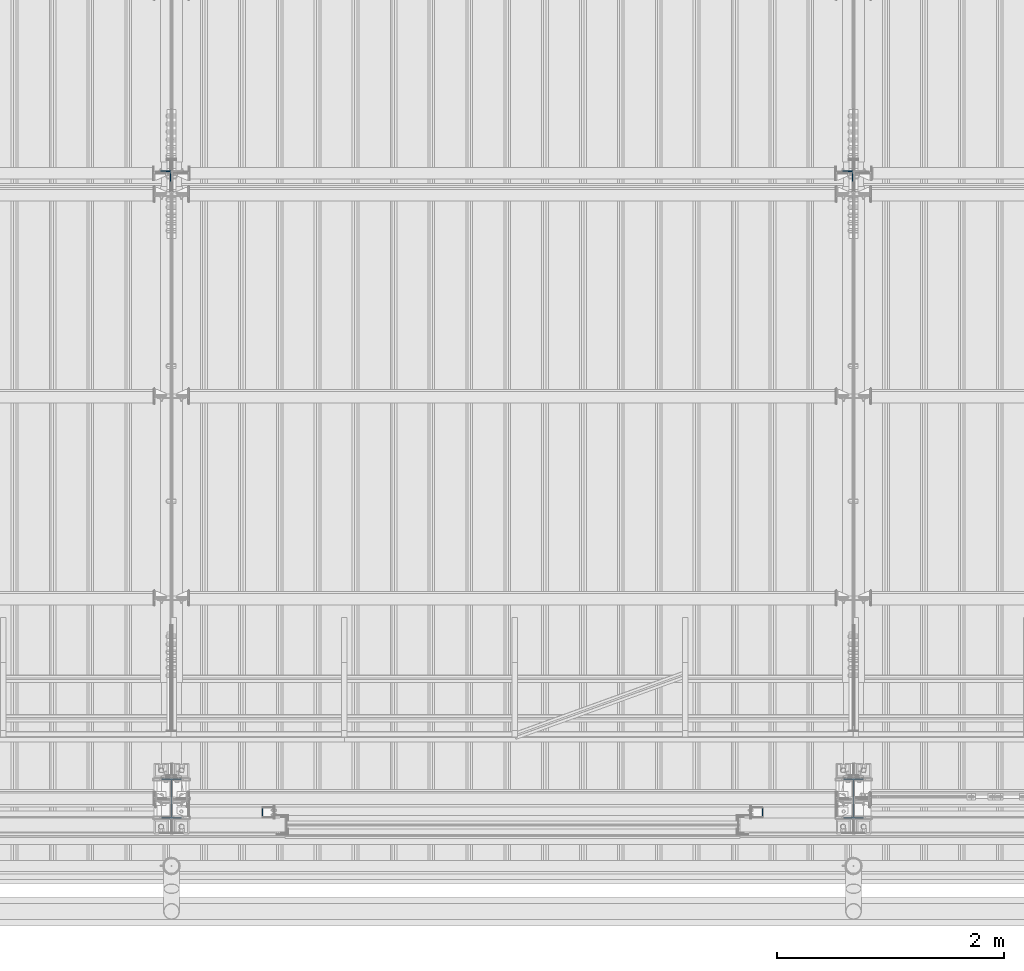
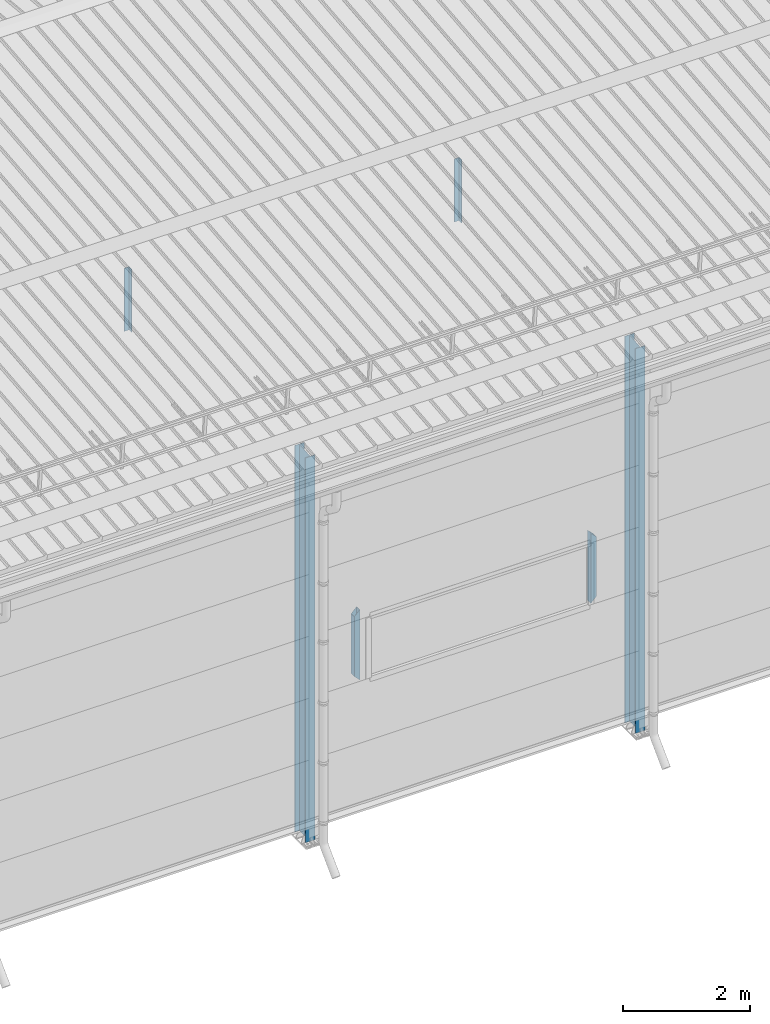
# One storey, part 228 of 709: 6 columns, 6 elements without a shape of their own.
"""IFC4 building model written with IfcOpenShell, lengths in millimetres."""

from ifc_helpers import new_model, si_unit, direction, frame, origin_with_axes, place, context, subcontext, project, spatial, polygons, material, element, aggregate, save


model = new_model("IFC4")

# Units and contexts
model_context = context("Model", 3, precision=0.2, world=origin_with_axes(), true_north=direction((0.0, 1.0)))
body_context = subcontext(model_context, "Body", "Model", "MODEL_VIEW")
ifc_project = project(units=[si_unit("LENGTHUNIT", "METRE", prefix="MILLI"), si_unit("AREAUNIT", "SQUARE_METRE"), si_unit("VOLUMEUNIT", "CUBIC_METRE"), si_unit("MASSUNIT", "GRAM", prefix="KILO"), si_unit("TIMEUNIT", "SECOND"), si_unit("PLANEANGLEUNIT", "RADIAN"), si_unit("SOLIDANGLEUNIT", "STERADIAN"), si_unit("THERMODYNAMICTEMPERATUREUNIT", "DEGREE_CELSIUS"), si_unit("LUMINOUSINTENSITYUNIT", "LUMEN")], contexts=[model_context])

# Site, building, storey
site_placement = place(None, origin_with_axes())
site = spatial("IfcSite", under=ifc_project, at=site_placement, CompositionType="ELEMENT")
building_placement = place(site_placement, origin_with_axes())
building = spatial("IfcBuilding", under=site, at=building_placement, Name="Undefined", CompositionType="ELEMENT")
storey_placement = place(building_placement, origin_with_axes())
storey = spatial("IfcBuildingStorey", under=building, at=storey_placement, Name="Undefined", CompositionType="ELEMENT", Elevation=0.0)

# Assembly, column
assembly_1_placement = place(storey_placement, frame((16000.0, 173.0, -200.0), z_axis=(-1.0, 0.0, 0.0), x_axis=(0.0, 0.0, 1.0)))
assembly_1 = element("IfcElementAssembly", 1, at=assembly_1_placement, inside=storey)
ifc_material_1 = material(Name="C355-5", Category="STEEL")
column_1_placement = place(assembly_1_placement, origin_with_axes())
column_1 = element("IfcColumn", 2, at=column_1_placement, material=ifc_material_1, ObjectType="413", context=body_context, shape_type="Tessellation", body=[
    polygons([(25.0, -173.0, -87.0), (25.0, -164.0, -87.0), (7421.82297, -164.0, -87.0), (7420.92297, -173.0, -87.0), (25.0, -164.0, -3.0), (7421.82297, -164.0, -3.0), (25.0, 164.0, -3.0), (7454.62297, 164.0, -3.0), (25.0, 164.0, -87.0), (7454.62297, 164.0, -87.0), (25.0, 173.0, -87.0), (7455.52297, 173.0, -87.0), (25.0, 173.0, 87.0), (7455.52297, 173.0, 87.0), (25.0, 164.0, 87.0), (7454.62297, 164.0, 87.0), (25.0, 164.0, 3.0), (7454.62297, 164.0, 3.0), (25.0, -164.0, 3.0), (7421.82297, -164.0, 3.0), (25.0, -164.0, 87.0), (7421.82297, -164.0, 87.0), (25.0, -173.0, 87.0), (7420.92297, -173.0, 87.0)], [[[1, 2, 3, 4]], [[2, 5, 6, 3]], [[5, 7, 8, 6]], [[7, 9, 10, 8]], [[9, 11, 12, 10]], [[11, 13, 14, 12]], [[13, 15, 16, 14]], [[15, 17, 18, 16]], [[17, 19, 20, 18]], [[19, 21, 22, 20]], [[21, 23, 24, 22]], [[23, 1, 4, 24]], [[6, 8, 10, 12, 14, 16, 18, 20, 22, 24, 4, 3]], [[23, 21, 19, 17, 15, 13, 11, 9, 7, 5, 2, 1]]], closed=True),
])
aggregate(assembly_1, [column_1])

assembly_2_placement = place(storey_placement, frame((15949.0, 5648.7, 6024.30002), z_axis=(0.0, -1.0, 0.0), x_axis=(0.0, 0.0, 1.0)))
assembly_2 = element("IfcElementAssembly", 3, at=assembly_2_placement, inside=storey)
ifc_material_2 = material(Name="C345-5", Category="STEEL")
column_2_placement = place(assembly_2_placement, origin_with_axes())
column_2 = element("IfcColumn", 4, at=column_2_placement, material=ifc_material_2, ObjectType="436", context=body_context, shape_type="Tessellation", body=[
    polygons([(185.7, -45.0, -45.0), (185.7, 45.0, -45.0), (1399.0509, 45.0, -45.0), (1399.0509, -45.0, -45.0), (185.7, 45.0, -39.0), (1399.0509, 45.0, -39.0), (185.7, -39.0, -39.0), (1399.0509, -39.0, -39.0), (185.7, -39.0, 45.0), (1399.0509, -39.0, 45.0), (185.7, -45.0, 45.0), (1399.0509, -45.0, 45.0)], [[[1, 2, 3, 4]], [[2, 5, 6, 3]], [[5, 7, 8, 6]], [[7, 9, 10, 8]], [[9, 11, 12, 10]], [[11, 1, 4, 12]], [[6, 8, 10, 12, 4, 3]], [[11, 9, 7, 5, 2, 1]]], closed=True),
])
aggregate(assembly_2, [column_2])

assembly_3_placement = place(storey_placement, frame((21949.0, 5648.7, 6024.30002), z_axis=(0.0, -1.0, 0.0), x_axis=(0.0, 0.0, 1.0)))
assembly_3 = element("IfcElementAssembly", 5, at=assembly_3_placement, inside=storey)
column_3_placement = place(assembly_3_placement, origin_with_axes())
column_3 = element("IfcColumn", 6, at=column_3_placement, material=ifc_material_2, ObjectType="436", context=body_context, shape_type="Tessellation", body=[
    polygons([(185.7, -45.0, -45.0), (185.7, 45.0, -45.0), (1399.0509, 45.0, -45.0), (1399.0509, -45.0, -45.0), (185.7, 45.0, -39.0), (1399.0509, 45.0, -39.0), (185.7, -39.0, -39.0), (1399.0509, -39.0, -39.0), (185.7, -39.0, 45.0), (1399.0509, -39.0, 45.0), (185.7, -45.0, 45.0), (1399.0509, -45.0, 45.0)], [[[1, 2, 3, 4]], [[2, 5, 6, 3]], [[5, 7, 8, 6]], [[7, 9, 10, 8]], [[9, 11, 12, 10]], [[11, 1, 4, 12]], [[6, 8, 10, 12, 4, 3]], [[11, 9, 7, 5, 2, 1]]], closed=True),
])
aggregate(assembly_3, [column_3])

assembly_4_placement = place(storey_placement, frame((16850.0, 50.0, 2600.0), z_axis=(1.0, 0.0, 0.0), x_axis=(0.0, 0.0, 1.0)))
assembly_4 = element("IfcElementAssembly", 7, at=assembly_4_placement, inside=storey)
ifc_material_3 = material(Name="C355", Category="STEEL")
column_4_placement = place(assembly_4_placement, origin_with_axes())
column_4 = element("IfcColumn", 8, at=column_4_placement, material=ifc_material_3, ObjectType="493", context=body_context, shape_type="Tessellation", body=[
    polygons([(10.0, -50.0, 50.0), (110.0, -50.0, -50.0), (1260.0, -50.0, -50.0), (1360.0, -50.0, 50.0), (10.0, 50.0, 50.0), (1360.0, 50.0, 50.0), (110.0, 50.0, -50.0), (1260.0, 50.0, -50.0), (13.0, -47.0, 47.0), (13.0, 47.0, 47.0), (1357.0, 47.0, 47.0), (1357.0, -47.0, 47.0), (107.0, -47.0, -47.0), (1263.0, -47.0, -47.0), (107.0, 47.0, -47.0), (1263.0, 47.0, -47.0)], [[[1, 2, 3, 4]], [[5, 1, 4, 6]], [[7, 5, 6, 8]], [[2, 7, 8, 3]], [[1, 5, 7, 2], [9, 13, 15, 10]], [[9, 10, 11, 12]], [[13, 9, 12, 14]], [[15, 13, 14, 16]], [[10, 15, 16, 11]], [[3, 8, 6, 4], [14, 12, 11, 16]]], closed=True),
])
aggregate(assembly_4, [column_4])

assembly_5_placement = place(storey_placement, frame((21150.0, 50.0, 2600.0), z_axis=(1.0, 0.0, 0.0), x_axis=(0.0, 0.0, 1.0)))
assembly_5 = element("IfcElementAssembly", 9, at=assembly_5_placement, inside=storey)
column_5_placement = place(assembly_5_placement, origin_with_axes())
column_5 = element("IfcColumn", 10, at=column_5_placement, material=ifc_material_3, ObjectType="493", context=body_context, shape_type="Tessellation", body=[
    polygons([(10.0, -50.0, -50.0), (10.0, 50.0, -50.0), (1360.0, 50.0, -50.0), (1360.0, -50.0, -50.0), (110.0, -50.0, 50.0), (1260.0, -50.0, 50.0), (110.0, 50.0, 50.0), (1260.0, 50.0, 50.0), (107.0, 47.0, 47.0), (13.0, 47.0, -47.0), (1357.0, 47.0, -47.0), (1263.0, 47.0, 47.0), (107.0, -47.0, 47.0), (1263.0, -47.0, 47.0), (13.0, -47.0, -47.0), (1357.0, -47.0, -47.0)], [[[1, 2, 3, 4]], [[5, 1, 4, 6]], [[7, 5, 6, 8]], [[2, 7, 8, 3]], [[1, 5, 7, 2], [15, 10, 9, 13]], [[9, 10, 11, 12]], [[13, 9, 12, 14]], [[15, 13, 14, 16]], [[10, 15, 16, 11]], [[6, 4, 3, 8], [14, 12, 11, 16]]], closed=True),
])
aggregate(assembly_5, [column_5])

assembly_6_placement = place(storey_placement, frame((22000.0, 173.0, -200.0), z_axis=(-1.0, 0.0, 0.0), x_axis=(0.0, 0.0, 1.0)))
assembly_6 = element("IfcElementAssembly", 11, at=assembly_6_placement, inside=storey)
column_6_placement = place(assembly_6_placement, origin_with_axes())
column_6 = element("IfcColumn", 12, at=column_6_placement, material=ifc_material_1, ObjectType="413", context=body_context, shape_type="Tessellation", body=[
    polygons([(25.0, -173.0, -87.0), (25.0, -164.0, -87.0), (7421.82297, -164.0, -87.0), (7420.92297, -173.0, -87.0), (25.0, -164.0, -3.0), (7421.82297, -164.0, -3.0), (25.0, 164.0, -3.0), (7454.62297, 164.0, -3.0), (25.0, 164.0, -87.0), (7454.62297, 164.0, -87.0), (25.0, 173.0, -87.0), (7455.52297, 173.0, -87.0), (25.0, 173.0, 87.0), (7455.52297, 173.0, 87.0), (25.0, 164.0, 87.0), (7454.62297, 164.0, 87.0), (25.0, 164.0, 3.0), (7454.62297, 164.0, 3.0), (25.0, -164.0, 3.0), (7421.82297, -164.0, 3.0), (25.0, -164.0, 87.0), (7421.82297, -164.0, 87.0), (25.0, -173.0, 87.0), (7420.92297, -173.0, 87.0)], [[[1, 2, 3, 4]], [[2, 5, 6, 3]], [[5, 7, 8, 6]], [[7, 9, 10, 8]], [[9, 11, 12, 10]], [[11, 13, 14, 12]], [[13, 15, 16, 14]], [[15, 17, 18, 16]], [[17, 19, 20, 18]], [[19, 21, 22, 20]], [[21, 23, 24, 22]], [[23, 1, 4, 24]], [[6, 8, 10, 12, 14, 16, 18, 20, 22, 24, 4, 3]], [[23, 21, 19, 17, 15, 13, 11, 9, 7, 5, 2, 1]]], closed=True),
])
aggregate(assembly_6, [column_6])

save(model, "model.ifc")
